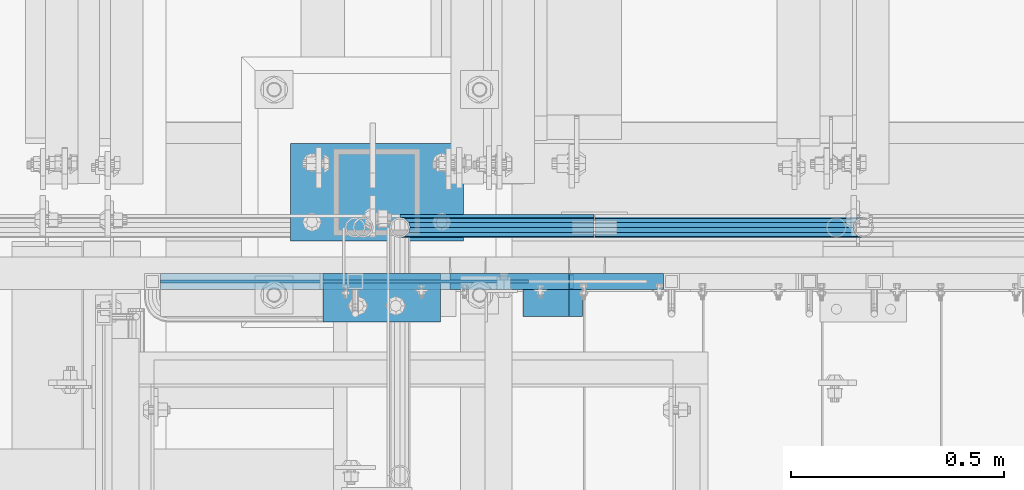
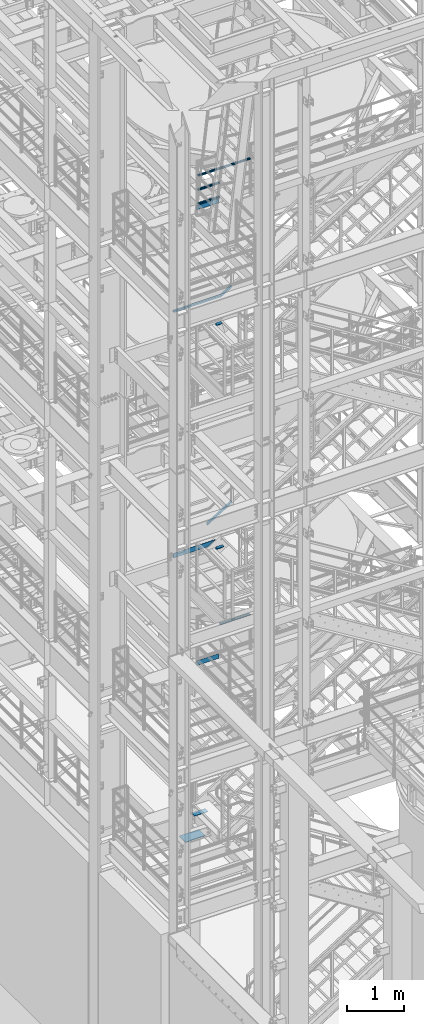
# One storey, part 1174 of 1876: 13 beams, 2 members, 10 elements without a shape of their own.
"""IFC2X3 building model written with IfcOpenShell, lengths in millimetres."""

from ifc_helpers import new_model, si_unit, frame, origin_with_axes, place, context, subcontext, project, spatial, faceted_brep, material, type_object, element, aggregate, save


model = new_model("IFC2X3")

# Units and contexts
model_context = context("Model", 3, precision=1e-05, world=origin_with_axes())
body_context = subcontext(model_context, "Body", "Model", "MODEL_VIEW")
ifc_project = project(units=[si_unit("LENGTHUNIT", "METRE", prefix="MILLI"), si_unit("AREAUNIT", "SQUARE_METRE"), si_unit("VOLUMEUNIT", "CUBIC_METRE"), si_unit("MASSUNIT", "GRAM", prefix="KILO"), si_unit("TIMEUNIT", "SECOND"), si_unit("PLANEANGLEUNIT", "RADIAN"), si_unit("SOLIDANGLEUNIT", "STERADIAN"), si_unit("THERMODYNAMICTEMPERATUREUNIT", "DEGREE_CELSIUS"), si_unit("LUMINOUSINTENSITYUNIT", "LUMEN")], contexts=[model_context])

# Site, building, storey
site_placement = place(None, origin_with_axes())
site = spatial("IfcSite", under=ifc_project, at=site_placement, CompositionType="ELEMENT")
building_placement = place(site_placement, origin_with_axes())
building = spatial("IfcBuilding", under=site, at=building_placement, Name="Undefined", CompositionType="ELEMENT")
storey_placement = place(building_placement, origin_with_axes())
storey = spatial("IfcBuildingStorey", under=building, at=storey_placement, Name="Undefined", CompositionType="ELEMENT", Elevation=0.0)

# Assembly, beams
assembly_1_placement = place(storey_placement, origin_with_axes())
assembly_1 = element("IfcElementAssembly", 1, at=assembly_1_placement, inside=storey, Name="RAIL", AssemblyPlace="NOTDEFINED", PredefinedType="RIGID_FRAME")
ifc_material_1 = material()
beam_type_1 = type_object("IfcBeamType", Name="PIPE1-1/2SCH40", PredefinedType="NOTDEFINED")
beam_1_placement = place(assembly_1_placement, frame((1781.17499999995, -4654.55000114554, 18754.725), z_axis=(0.0, 0.0, 1.0), x_axis=(1.0, 0.0, 0.0)))
beam_1 = element("IfcBeam", 2, at=beam_1_placement, type_object=beam_type_1, material=ifc_material_1, Name="RAIL", ObjectType="PIPE1-1/2SCH40", context=body_context, shape_type="Brep", body=[
    faceted_brep([(0.0, 24.1299999999992, 0.0), (12.0650000000064, 20.8971929933177, -12.0649999999987), (12.0650000000064, 20.8971929933177, 12.0649999999987), (12.0650000000064, -20.8971929933177, 12.0649999999987), (12.0650000000064, -20.8971929933177, -12.0649999999987), (0.0, -24.1299999999992, 0.0), (20.8971929933249, -12.0650000000005, 20.8971929933177), (20.8971929933249, -12.0650000000005, 15.8661214311796), (15.2545715621445, -17.7076214311801, 10.2235000000001), (12.5151929933249, -20.4470000000001, 0.0), (15.2545715621445, -17.7076214311801, -10.2235000000001), (20.8971929933249, -12.0650000000005, -15.8661214311796), (20.8971929933249, -12.0650000000005, -20.8971929933177), (24.1300000000063, 0.0, -20.4470000000001), (24.1300000000063, 0.0, -24.130000000001), (21.3906214311868, -10.2235000000001, -17.7076214311819), (21.3906214311868, 10.2235000000001, -17.7076214311819), (20.8971929933249, 12.0650000000005, -15.8661214311796), (20.8971929933249, 12.0650000000005, -20.8971929933177), (15.2545715621445, 17.7076214311801, -10.2235000000001), (12.5151929933249, 20.4470000000001, 0.0), (15.2545715621445, 17.7076214311801, 10.2235000000001), (20.8971929933249, 12.0650000000005, 15.8661214311796), (20.8971929933249, 12.0650000000005, 20.8971929933177), (21.3906214311868, 10.2235000000001, 17.7076214311819), (24.1300000000064, 0.0, 20.4470000000001), (24.1300000000064, 0.0, 24.130000000001), (21.3906214311868, -10.2235000000001, 17.7076214311819), (455.612999922148, -24.1300000000001, 0.0), (455.612999922148, -20.8971929933186, 12.0649999999996), (455.612999922148, -12.0649999999996, 20.8971929933186), (455.612999922148, 0.0, 24.1300000000001), (455.612999922148, -12.0649999999996, -20.8971929933186), (455.612999922148, -20.8971929933186, -12.0649999999996), (455.612999922148, 0.0, -24.1300000000001), (455.612999922148, 12.0649999999996, -20.8971929933186), (455.612999922148, 20.8971929933186, -12.0649999999996), (455.612999922148, 24.1300000000001, 0.0), (455.612999922148, 20.8971929933186, 12.0649999999996), (455.612999922148, 12.0649999999996, 20.8971929933186), (455.612999922148, -10.2235000000001, 17.7076214311801), (455.612999922148, 0.0, 20.4470000000001), (455.612999922148, 10.2235000000001, 17.7076214311801), (455.612999922148, 17.7076214311801, 10.2235000000001), (455.612999922148, 20.4470000000001, 0.0), (455.612999922148, 17.7076214311801, -10.2235000000001), (455.612999922148, 10.2235000000001, -17.7076214311801), (455.612999922148, 0.0, -20.4470000000001), (455.612999922148, -10.2235000000001, -17.7076214311801), (455.612999922148, -17.7076214311801, -10.2235000000001), (455.612999922148, -20.4470000000001, 0.0), (455.612999922148, -17.7076214311801, 10.2235000000001)], [[[0, 1, 2]], [[3, 4, 5]], [[6, 7, 8, 9, 10, 11, 12, 4, 3]], [[13, 14, 12, 11, 15]], [[16, 17, 18, 14, 13]], [[2, 1, 18, 17, 19, 20, 21, 22, 23]], [[23, 22, 24, 25, 26]], [[26, 25, 27, 7, 6]], [[28, 29, 3, 5]], [[29, 30, 6, 3]], [[30, 31, 26, 6]], [[32, 33, 4, 12]], [[34, 32, 12, 14]], [[35, 34, 14, 18]], [[36, 35, 18, 1]], [[37, 36, 1, 0]], [[38, 37, 0, 2]], [[39, 38, 2, 23]], [[31, 39, 23, 26]], [[33, 28, 5, 4]], [[32, 34, 35, 36, 37, 38, 39, 31, 30, 29, 28, 33], [40, 41, 42, 43, 44, 45, 46, 47, 48, 49, 50, 51]], [[42, 41, 25, 24]], [[21, 43, 42, 24, 22]], [[44, 43, 21, 20]], [[45, 44, 20, 19]], [[46, 45, 19, 17, 16]], [[47, 46, 16, 13]], [[48, 47, 13, 15]], [[10, 49, 48, 15, 11]], [[50, 49, 10, 9]], [[51, 50, 9, 8]], [[40, 51, 8, 7, 27]], [[41, 40, 27, 25]]]),
])
beam_2_placement = place(assembly_1_placement, frame((1781.17499999995, -4654.55000114555, 18449.925), z_axis=(0.0, 0.0, 1.0), x_axis=(1.0, 0.0, 0.0)))
beam_2 = element("IfcBeam", 3, at=beam_2_placement, type_object=beam_type_1, material=ifc_material_1, Name="RAIL", ObjectType="PIPE1-1/2SCH40", context=body_context, shape_type="Brep", body=[
    faceted_brep([(0.0, 24.1299999999992, 0.0), (12.0650000000064, 20.8971929933177, -12.0649999999987), (12.0650000000064, 20.8971929933177, 12.0649999999987), (12.0650000000064, -20.8971929933177, 12.0649999999987), (12.0650000000064, -20.8971929933177, -12.0649999999987), (0.0, -24.1299999999992, 0.0), (20.8971929933249, -12.0650000000005, 20.8971929933177), (20.8971929933249, -12.0650000000005, 15.8661214311796), (15.2545715621445, -17.7076214311801, 10.2235000000001), (12.5151929933249, -20.4470000000001, 0.0), (15.2545715621445, -17.7076214311801, -10.2235000000001), (20.8971929933249, -12.0650000000005, -15.8661214311796), (20.8971929933249, -12.0650000000005, -20.8971929933177), (24.1300000000063, 0.0, -20.4470000000001), (24.1300000000063, 0.0, -24.130000000001), (21.3906214311868, -10.2235000000001, -17.7076214311819), (21.3906214311868, 10.2235000000001, -17.7076214311819), (20.8971929933249, 12.0650000000005, -15.8661214311796), (20.8971929933249, 12.0650000000005, -20.8971929933177), (15.2545715621445, 17.7076214311801, -10.2235000000001), (12.5151929933249, 20.4470000000001, 0.0), (15.2545715621445, 17.7076214311801, 10.2235000000001), (20.8971929933249, 12.0650000000005, 15.8661214311796), (20.8971929933249, 12.0650000000005, 20.8971929933177), (21.3906214311868, 10.2235000000001, 17.7076214311819), (24.1300000000064, 0.0, 20.4470000000001), (24.1300000000064, 0.0, 24.130000000001), (21.3906214311868, -10.2235000000001, 17.7076214311819), (455.612999922148, -24.1300000000001, 0.0), (455.612999922148, -20.8971929933186, 12.0649999999996), (455.612999922148, -12.0649999999996, 20.8971929933186), (455.612999922148, 0.0, 24.1300000000001), (455.612999922148, -12.0649999999996, -20.8971929933186), (455.612999922148, -20.8971929933186, -12.0649999999996), (455.612999922148, 0.0, -24.1300000000001), (455.612999922148, 12.0649999999996, -20.8971929933186), (455.612999922148, 20.8971929933186, -12.0649999999996), (455.612999922148, 24.1300000000001, 0.0), (455.612999922148, 20.8971929933186, 12.0649999999996), (455.612999922148, 12.0649999999996, 20.8971929933186), (455.612999922148, -10.2235000000001, 17.7076214311801), (455.612999922148, 0.0, 20.4470000000001), (455.612999922148, 10.2235000000001, 17.7076214311801), (455.612999922148, 17.7076214311801, 10.2235000000001), (455.612999922148, 20.4470000000001, 0.0), (455.612999922148, 17.7076214311801, -10.2235000000001), (455.612999922148, 10.2235000000001, -17.7076214311801), (455.612999922148, 0.0, -20.4470000000001), (455.612999922148, -10.2235000000001, -17.7076214311801), (455.612999922148, -17.7076214311801, -10.2235000000001), (455.612999922148, -20.4470000000001, 0.0), (455.612999922148, -17.7076214311801, 10.2235000000001)], [[[0, 1, 2]], [[3, 4, 5]], [[6, 7, 8, 9, 10, 11, 12, 4, 3]], [[13, 14, 12, 11, 15]], [[16, 17, 18, 14, 13]], [[2, 1, 18, 17, 19, 20, 21, 22, 23]], [[23, 22, 24, 25, 26]], [[26, 25, 27, 7, 6]], [[28, 29, 3, 5]], [[29, 30, 6, 3]], [[30, 31, 26, 6]], [[32, 33, 4, 12]], [[34, 32, 12, 14]], [[35, 34, 14, 18]], [[36, 35, 18, 1]], [[37, 36, 1, 0]], [[38, 37, 0, 2]], [[39, 38, 2, 23]], [[31, 39, 23, 26]], [[33, 28, 5, 4]], [[32, 34, 35, 36, 37, 38, 39, 31, 30, 29, 28, 33], [40, 41, 42, 43, 44, 45, 46, 47, 48, 49, 50, 51]], [[42, 41, 25, 24]], [[21, 43, 42, 24, 22]], [[44, 43, 21, 20]], [[45, 44, 20, 19]], [[46, 45, 19, 17, 16]], [[47, 46, 16, 13]], [[48, 47, 13, 15]], [[10, 49, 48, 15, 11]], [[50, 49, 10, 9]], [[51, 50, 9, 8]], [[40, 51, 8, 7, 27]], [[41, 40, 27, 25]]]),
])
beam_3_placement = place(assembly_1_placement, frame((1781.175, -4654.55000114554, 18145.125), z_axis=(0.0, 0.0, 1.0), x_axis=(1.0, 0.0, 0.0)))
beam_3 = element("IfcBeam", 4, at=beam_3_placement, type_object=beam_type_1, material=ifc_material_1, Name="RAIL", ObjectType="PIPE1-1/2SCH40", context=body_context, shape_type="Brep", body=[
    faceted_brep([(0.0, 24.1299999999992, 0.0), (12.0650000000064, 20.8971929933177, -12.0649999999987), (12.0650000000064, 20.8971929933177, 12.0649999999987), (12.0650000000064, -20.8971929933177, 12.0649999999987), (12.0650000000064, -20.8971929933177, -12.0649999999987), (0.0, -24.1299999999992, 0.0), (20.8971929933249, -12.0650000000005, 20.8971929933177), (20.8971929933249, -12.0650000000005, 15.8661214311796), (15.2545715621445, -17.7076214311801, 10.2235000000001), (12.5151929933249, -20.4470000000001, 0.0), (15.2545715621445, -17.7076214311801, -10.2235000000001), (20.8971929933249, -12.0650000000005, -15.8661214311796), (20.8971929933249, -12.0650000000005, -20.8971929933177), (24.1300000000063, 0.0, -20.4470000000001), (24.1300000000063, 0.0, -24.130000000001), (21.3906214311868, -10.2235000000001, -17.7076214311819), (21.3906214311868, 10.2235000000001, -17.7076214311819), (20.8971929933249, 12.0650000000005, -15.8661214311796), (20.8971929933249, 12.0650000000005, -20.8971929933177), (15.2545715621445, 17.7076214311801, -10.2235000000001), (12.5151929933249, 20.4470000000001, 0.0), (15.2545715621445, 17.7076214311801, 10.2235000000001), (20.8971929933249, 12.0650000000005, 15.8661214311796), (20.8971929933249, 12.0650000000005, 20.8971929933177), (21.3906214311868, 10.2235000000001, 17.7076214311819), (24.1300000000064, 0.0, 20.4470000000001), (24.1300000000064, 0.0, 24.130000000001), (21.3906214311868, -10.2235000000001, 17.7076214311819), (455.612999922148, -24.1300000000001, 0.0), (455.612999922148, -20.8971929933186, 12.0649999999996), (455.612999922148, -12.0649999999996, 20.8971929933186), (455.612999922148, 0.0, 24.1300000000001), (455.612999922148, -12.0649999999996, -20.8971929933186), (455.612999922148, -20.8971929933186, -12.0649999999996), (455.612999922148, 0.0, -24.1300000000001), (455.612999922148, 12.0649999999996, -20.8971929933186), (455.612999922148, 20.8971929933186, -12.0649999999996), (455.612999922148, 24.1300000000001, 0.0), (455.612999922148, 20.8971929933186, 12.0649999999996), (455.612999922148, 12.0649999999996, 20.8971929933186), (455.612999922148, -10.2235000000001, 17.7076214311801), (455.612999922148, 0.0, 20.4470000000001), (455.612999922148, 10.2235000000001, 17.7076214311801), (455.612999922148, 17.7076214311801, 10.2235000000001), (455.612999922148, 20.4470000000001, 0.0), (455.612999922148, 17.7076214311801, -10.2235000000001), (455.612999922148, 10.2235000000001, -17.7076214311801), (455.612999922148, 0.0, -20.4470000000001), (455.612999922148, -10.2235000000001, -17.7076214311801), (455.612999922148, -17.7076214311801, -10.2235000000001), (455.612999922148, -20.4470000000001, 0.0), (455.612999922148, -17.7076214311801, 10.2235000000001)], [[[0, 1, 2]], [[3, 4, 5]], [[6, 7, 8, 9, 10, 11, 12, 4, 3]], [[13, 14, 12, 11, 15]], [[16, 17, 18, 14, 13]], [[2, 1, 18, 17, 19, 20, 21, 22, 23]], [[23, 22, 24, 25, 26]], [[26, 25, 27, 7, 6]], [[28, 29, 3, 5]], [[29, 30, 6, 3]], [[30, 31, 26, 6]], [[32, 33, 4, 12]], [[34, 32, 12, 14]], [[35, 34, 14, 18]], [[36, 35, 18, 1]], [[37, 36, 1, 0]], [[38, 37, 0, 2]], [[39, 38, 2, 23]], [[31, 39, 23, 26]], [[33, 28, 5, 4]], [[32, 34, 35, 36, 37, 38, 39, 31, 30, 29, 28, 33], [40, 41, 42, 43, 44, 45, 46, 47, 48, 49, 50, 51]], [[42, 41, 25, 24]], [[21, 43, 42, 24, 22]], [[44, 43, 21, 20]], [[45, 44, 20, 19]], [[46, 45, 19, 17, 16]], [[47, 46, 16, 13]], [[48, 47, 13, 15]], [[10, 49, 48, 15, 11]], [[50, 49, 10, 9]], [[51, 50, 9, 8]], [[40, 51, 8, 7, 27]], [[41, 40, 27, 25]]]),
])

# Assembly, beam
assembly_2_placement = place(storey_placement, origin_with_axes())
assembly_2 = element("IfcElementAssembly", 5, at=assembly_2_placement, inside=storey, Name="RAIL", AssemblyPlace="NOTDEFINED", PredefinedType="RIGID_FRAME")
beam_4_placement = place(assembly_2_placement, frame((2238.37499998823, -4654.55000114554, 8924.925), z_axis=(0.0, 0.0, -1.0), x_axis=(1.0, 0.0, 0.0)))
beam_4 = element("IfcBeam", 6, at=beam_4_placement, type_object=beam_type_1, material=ifc_material_1, Name="RAIL", ObjectType="PIPE1-1/2SCH40", context=body_context, shape_type="Brep", body=[
    faceted_brep([(610.92780700668, -12.0649999999996, 20.8971929933177), (610.92780700668, -12.0650000000051, 15.866121431176), (610.434378568817, -10.2235000000001, 17.7076214311819), (607.694999999998, 0.0, 20.4470000000001), (607.694999999998, 0.0, 24.130000000001), (610.434378568819, 10.2235000000001, 17.7076214311819), (610.92780700668, 12.0649999999941, 15.8661214311869), (610.92780700668, 12.0649999999996, 20.8971929933177), (631.825, 24.1300000000001, 0.0), (619.759999999998, 20.8971929933186, 12.0649999999987), (619.759999999998, 20.8971929933186, -12.0649999999987), (616.570428437866, 17.7076214311801, 10.2235000000001), (619.309807006685, 20.4470000000001, 0.0), (616.570428437866, 17.7076214311801, -10.2235000000001), (610.92780700668, 12.0649999999941, -15.8661214311869), (610.92780700668, 12.0649999999996, -20.8971929933177), (610.434378568819, 10.2235000000001, -17.7076214311819), (607.694999999998, 0.0, -20.4470000000001), (607.694999999998, 0.0, -24.130000000001), (610.92780700668, -12.0650000000051, -15.866121431176), (610.92780700668, -12.0649999999996, -20.8971929933177), (610.434378568817, -10.2235000000001, -17.7076214311819), (631.824999999998, -24.1300000000056, 0.0), (619.759999999998, -20.8971929933186, -12.0649999999987), (619.759999999998, -20.8971929933186, 12.0649999999987), (616.570428437855, -17.7076214311801, -10.2235000000001), (619.309807006674, -20.4470000000001, 0.0), (616.570428437855, -17.7076214311801, 10.2235000000001), (1.58700000000044, -20.8971929933186, -12.0649999999996), (1.58700000000044, -12.0649999999996, -20.8971929933186), (1.58700000000044, 0.0, -24.1300000000001), (1.58700000000044, 12.0649999999996, -20.8971929933186), (1.58700000000044, 20.8971929933186, -12.0649999999996), (1.58700000000044, 24.1300000000001, 0.0), (1.58700000000044, 20.8971929933186, 12.0649999999996), (1.58700000000044, 12.0649999999996, 20.8971929933186), (1.58700000000044, 0.0, 24.1300000000001), (1.58700000000044, -12.0649999999996, 20.8971929933186), (1.58700000000044, -20.8971929933186, 12.0649999999996), (1.58700000000044, -24.1300000000001, 0.0), (1.58700000000044, -17.7076214311801, -10.2235000000001), (1.58700000000044, -10.2235000000001, -17.7076214311801), (1.58700000000044, 0.0, -20.4470000000001), (1.58700000000044, 10.2235000000001, -17.7076214311801), (1.58700000000044, 17.7076214311801, -10.2235000000001), (1.58700000000044, 20.4470000000001, 0.0), (1.58700000000044, 17.7076214311801, 10.2235000000001), (1.58700000000044, 10.2235000000001, 17.7076214311801), (1.58700000000044, 0.0, 20.4470000000001), (1.58700000000044, -10.2235000000001, 17.7076214311801), (1.58700000000044, -17.7076214311801, 10.2235000000001), (1.58700000000044, -20.4470000000001, 0.0)], [[[0, 1, 2, 3, 4]], [[4, 3, 5, 6, 7]], [[8, 9, 10]], [[7, 6, 11, 12, 13, 14, 15, 10, 9]], [[16, 17, 18, 15, 14]], [[19, 20, 18, 17, 21]], [[22, 23, 24]], [[24, 23, 20, 19, 25, 26, 27, 1, 0]], [[28, 29, 20, 23]], [[29, 30, 18, 20]], [[30, 31, 15, 18]], [[31, 32, 10, 15]], [[32, 33, 8, 10]], [[33, 34, 9, 8]], [[34, 35, 7, 9]], [[35, 36, 4, 7]], [[36, 37, 0, 4]], [[37, 38, 24, 0]], [[38, 39, 22, 24]], [[39, 28, 23, 22]], [[38, 37, 36, 35, 34, 33, 32, 31, 30, 29, 28, 39], [40, 41, 42, 43, 44, 45, 46, 47, 48, 49, 50, 51]], [[40, 51, 26, 25]], [[21, 41, 40, 25, 19]], [[42, 41, 21, 17]], [[43, 42, 17, 16]], [[44, 43, 16, 14, 13]], [[45, 44, 13, 12]], [[46, 45, 12, 11]], [[5, 47, 46, 11, 6]], [[48, 47, 5, 3]], [[49, 48, 3, 2]], [[50, 49, 2, 1, 27]], [[51, 50, 27, 26]]]),
])
aggregate(assembly_2, [beam_4])

assembly_3_placement = place(storey_placement, origin_with_axes())
assembly_3 = element("IfcElementAssembly", 7, at=assembly_3_placement, inside=storey, Name="RAIL", AssemblyPlace="NOTDEFINED", PredefinedType="RIGID_FRAME")
beam_5_placement = place(assembly_3_placement, frame((2238.37499998823, -4654.55000114554, 18754.725), z_axis=(0.0, 0.0, -1.0), x_axis=(1.0, 0.0, 0.0)))
beam_5 = element("IfcBeam", 8, at=beam_5_placement, type_object=beam_type_1, material=ifc_material_1, Name="RAIL", ObjectType="PIPE1-1/2SCH40", context=body_context, shape_type="Brep", body=[
    faceted_brep([(610.92780700668, -12.0649999999996, 20.8971929933177), (610.92780700668, -12.0650000000051, 15.866121431176), (610.434378568817, -10.2235000000001, 17.7076214311819), (607.694999999998, 0.0, 20.4470000000001), (607.694999999998, 0.0, 24.130000000001), (610.434378568819, 10.2235000000001, 17.7076214311819), (610.92780700668, 12.0649999999941, 15.8661214311869), (610.92780700668, 12.0649999999996, 20.8971929933177), (631.825, 24.1300000000001, 0.0), (619.759999999998, 20.8971929933186, 12.0649999999987), (619.759999999998, 20.8971929933186, -12.0649999999987), (616.570428437866, 17.7076214311801, 10.2235000000001), (619.309807006685, 20.4470000000001, 0.0), (616.570428437866, 17.7076214311801, -10.2235000000001), (610.92780700668, 12.0649999999941, -15.8661214311869), (610.92780700668, 12.0649999999996, -20.8971929933177), (610.434378568819, 10.2235000000001, -17.7076214311819), (607.694999999998, 0.0, -20.4470000000001), (607.694999999998, 0.0, -24.130000000001), (610.92780700668, -12.0650000000051, -15.866121431176), (610.92780700668, -12.0649999999996, -20.8971929933177), (610.434378568817, -10.2235000000001, -17.7076214311819), (631.824999999998, -24.1300000000056, 0.0), (619.759999999998, -20.8971929933186, -12.0649999999987), (619.759999999998, -20.8971929933186, 12.0649999999987), (616.570428437855, -17.7076214311801, -10.2235000000001), (619.309807006674, -20.4470000000001, 0.0), (616.570428437855, -17.7076214311801, 10.2235000000001), (1.58700000000044, -20.8971929933186, -12.0649999999996), (1.58700000000044, -12.0649999999996, -20.8971929933186), (1.58700000000044, 0.0, -24.1300000000001), (1.58700000000044, 12.0649999999996, -20.8971929933186), (1.58700000000044, 20.8971929933186, -12.0649999999996), (1.58700000000044, 24.1300000000001, 0.0), (1.58700000000044, 20.8971929933186, 12.0649999999996), (1.58700000000044, 12.0649999999996, 20.8971929933186), (1.58700000000044, 0.0, 24.1300000000001), (1.58700000000044, -12.0649999999996, 20.8971929933186), (1.58700000000044, -20.8971929933186, 12.0649999999996), (1.58700000000044, -24.1300000000001, 0.0), (1.58700000000044, -17.7076214311801, -10.2235000000001), (1.58700000000044, -10.2235000000001, -17.7076214311801), (1.58700000000044, 0.0, -20.4470000000001), (1.58700000000044, 10.2235000000001, -17.7076214311801), (1.58700000000044, 17.7076214311801, -10.2235000000001), (1.58700000000044, 20.4470000000001, 0.0), (1.58700000000044, 17.7076214311801, 10.2235000000001), (1.58700000000044, 10.2235000000001, 17.7076214311801), (1.58700000000044, 0.0, 20.4470000000001), (1.58700000000044, -10.2235000000001, 17.7076214311801), (1.58700000000044, -17.7076214311801, 10.2235000000001), (1.58700000000044, -20.4470000000001, 0.0)], [[[0, 1, 2, 3, 4]], [[4, 3, 5, 6, 7]], [[8, 9, 10]], [[7, 6, 11, 12, 13, 14, 15, 10, 9]], [[16, 17, 18, 15, 14]], [[19, 20, 18, 17, 21]], [[22, 23, 24]], [[24, 23, 20, 19, 25, 26, 27, 1, 0]], [[28, 29, 20, 23]], [[29, 30, 18, 20]], [[30, 31, 15, 18]], [[31, 32, 10, 15]], [[32, 33, 8, 10]], [[33, 34, 9, 8]], [[34, 35, 7, 9]], [[35, 36, 4, 7]], [[36, 37, 0, 4]], [[37, 38, 24, 0]], [[38, 39, 22, 24]], [[39, 28, 23, 22]], [[38, 37, 36, 35, 34, 33, 32, 31, 30, 29, 28, 39], [40, 41, 42, 43, 44, 45, 46, 47, 48, 49, 50, 51]], [[40, 51, 26, 25]], [[21, 41, 40, 25, 19]], [[42, 41, 21, 17]], [[43, 42, 17, 16]], [[44, 43, 16, 14, 13]], [[45, 44, 13, 12]], [[46, 45, 12, 11]], [[5, 47, 46, 11, 6]], [[48, 47, 5, 3]], [[49, 48, 3, 2]], [[50, 49, 2, 1, 27]], [[51, 50, 27, 26]]]),
])
aggregate(assembly_3, [beam_5])

assembly_4_placement = place(storey_placement, origin_with_axes())
assembly_4 = element("IfcElementAssembly", 9, at=assembly_4_placement, inside=storey, Name="STRINGER", AssemblyPlace="NOTDEFINED", PredefinedType="RIGID_FRAME")
ifc_material_2 = material(Name="STEEL/A36")
beam_type_2 = type_object("IfcBeamType", Name="L2-1/2X2-1/2X1/4", PredefinedType="NOTDEFINED")
beam_6_placement = place(assembly_4_placement, frame((2070.10000004636, -4832.34999887687, 15531.2768518519), z_axis=(0.0, -1.0, 0.0), x_axis=(1.0, 0.0, 0.0)))
beam_6 = element("IfcBeam", 10, at=beam_6_placement, type_object=beam_type_2, material=ifc_material_2, Name="ANGLE", ObjectType="L2-1/2X2-1/2X1/4", context=body_context, shape_type="Brep", body=[
    faceted_brep([(0.0, 31.75, -31.75), (0.0, 31.75, 31.75), (107.95007324219, 31.7500000000491, 31.75), (107.95007324219, 31.7500000000491, -31.75), (0.0, 25.3999999999996, 31.75), (107.950073242189, 25.4000000000487, 31.75), (0.0, 25.3999999999996, -25.3999999999996), (107.950073242189, 25.4000000000487, -25.3999999999996), (0.0, -31.75, -25.3999999999996), (107.950073242189, -31.7499999999509, -25.3999999999996), (0.0, -31.75, -31.75), (107.950073242189, -31.7499999999509, -31.75)], [[[0, 1, 2, 3]], [[1, 4, 5, 2]], [[4, 6, 7, 5]], [[6, 8, 9, 7]], [[8, 10, 11, 9]], [[10, 0, 3, 11]], [[5, 7, 9, 11, 3, 2]], [[10, 8, 6, 4, 1, 0]]]),
])
aggregate(assembly_4, [beam_6])

assembly_5_placement = place(storey_placement, origin_with_axes())
assembly_5 = element("IfcElementAssembly", 11, at=assembly_5_placement, inside=storey, Name="STRINGER", AssemblyPlace="NOTDEFINED", PredefinedType="RIGID_FRAME")
beam_7_placement = place(assembly_5_placement, frame((2070.1000003697, -4832.34999887637, 10702.925), z_axis=(0.0, -1.0, 0.0), x_axis=(1.0, 0.0, 0.0)))
beam_7 = element("IfcBeam", 12, at=beam_7_placement, type_object=beam_type_2, material=ifc_material_2, Name="ANGLE", ObjectType="L2-1/2X2-1/2X1/4", context=body_context, shape_type="Brep", body=[
    faceted_brep([(0.0, 31.75, -31.75), (0.0, 31.75, 31.75), (139.700073242188, 31.75, 31.75), (139.700073242188, 31.75, -31.75), (0.0, 25.3999999999996, 31.75), (139.700073242188, 25.3999999999996, 31.75), (0.0, 25.3999999999996, -25.3999999999996), (139.700073242188, 25.3999999999996, -25.3999999999996), (0.0, -31.75, -25.3999999999996), (139.700073242188, -31.75, -25.3999999999996), (0.0, -31.75, -31.75), (139.700073242188, -31.75, -31.75)], [[[0, 1, 2, 3]], [[1, 4, 5, 2]], [[4, 6, 7, 5]], [[6, 8, 9, 7]], [[8, 10, 11, 9]], [[10, 0, 3, 11]], [[5, 7, 9, 11, 3, 2]], [[10, 8, 6, 4, 1, 0]]]),
])
aggregate(assembly_5, [beam_7])

assembly_6_placement = place(storey_placement, origin_with_axes())
assembly_6 = element("IfcElementAssembly", 13, at=assembly_6_placement, inside=storey, Name="RAIL", AssemblyPlace="NOTDEFINED", PredefinedType="RIGID_FRAME")
beam_type_3 = type_object("IfcBeamType", PredefinedType="NOTDEFINED")
beam_8_placement = place(assembly_6_placement, frame((1781.175, -4627.56250191054, 8220.075), z_axis=(0.0, 0.0, 1.0), x_axis=(1.0, 0.0, 0.0)))
beam_8 = element("IfcBeam", 14, at=beam_8_placement, type_object=beam_type_3, material=ifc_material_2, Name="PLATE", context=body_context, shape_type="Brep", body=[
    faceted_brep([(0.0, 3.17500000000018, -50.8000000000002), (0.0, 3.17500000000018, 50.8000000000002), (455.612499988232, 3.17500000000018, 50.7999999999993), (455.612499988232, 3.17500000000018, -50.8000000000002), (0.0, -3.17500000000018, 50.8000000000002), (455.612499988232, -3.17500000000018, 50.7999999999993), (0.0, -3.17500000000018, -50.8000000000002), (455.612499988232, -3.17500000000018, -50.8000000000002)], [[[0, 1, 2, 3]], [[1, 4, 5, 2]], [[4, 6, 7, 5]], [[6, 0, 3, 7]], [[5, 7, 3, 2]], [[6, 4, 1, 0]]]),
])
aggregate(assembly_6, [beam_8])

# Beam
beam_9_placement = place(assembly_1_placement, frame((1781.175, -4627.56250191054, 18049.875), z_axis=(0.0, 0.0, 1.0), x_axis=(1.0, 0.0, 0.0)))
beam_9 = element("IfcBeam", 15, at=beam_9_placement, type_object=beam_type_3, material=ifc_material_2, Name="PLATE", context=body_context, shape_type="Brep", body=[
    faceted_brep([(0.0, 3.17500000000018, -50.8000000000002), (0.0, 3.17500000000018, 50.8000000000002), (455.612499988232, 3.17500000000018, 50.7999999999993), (455.612499988232, 3.17500000000018, -50.8000000000002), (0.0, -3.17500000000018, 50.8000000000002), (455.612499988232, -3.17500000000018, 50.7999999999993), (0.0, -3.17500000000018, -50.8000000000002), (455.612499988232, -3.17500000000018, -50.8000000000002)], [[[0, 1, 2, 3]], [[1, 4, 5, 2]], [[4, 6, 7, 5]], [[6, 0, 3, 7]], [[5, 7, 3, 2]], [[6, 4, 1, 0]]]),
])

aggregate(assembly_1, [beam_1, beam_2, beam_3, beam_9])

# Assembly, beam
assembly_7_placement = place(storey_placement, origin_with_axes())
assembly_7 = element("IfcElementAssembly", 16, at=assembly_7_placement, inside=storey, Name="RAIL", AssemblyPlace="NOTDEFINED", PredefinedType="RIGID_FRAME")
beam_10_placement = place(assembly_7_placement, frame((1219.19999961062, -4781.55000191421, 10829.9249989614), z_axis=(0.0, 0.0, 1.0), x_axis=(1.0, 0.0, 0.0)))
beam_10 = element("IfcBeam", 17, at=beam_10_placement, type_object=beam_type_3, material=ifc_material_2, Name="PLATE", context=body_context, shape_type="Brep", body=[
    faceted_brep([(0.0, 3.17500000000018, -50.8000000000002), (0.0, 3.17500000000018, 50.8000000000002), (864.420929595873, 3.17500000000018, 50.7999999999993), (699.258368074921, 3.17500000000018, -50.7999999999993), (0.0, -3.17500000000018, 50.8000000000002), (864.420929595873, -3.17500000000018, 50.7999999999993), (0.0, -3.17500000000018, -50.8000000000002), (699.258368074921, -3.17500000000018, -50.7999999999993)], [[[0, 1, 2, 3]], [[1, 4, 5, 2]], [[4, 6, 7, 5]], [[6, 0, 3, 7]], [[5, 7, 3, 2]], [[6, 4, 1, 0]]]),
])

assembly_8_placement = place(storey_placement, origin_with_axes())
assembly_8 = element("IfcElementAssembly", 18, at=assembly_8_placement, inside=storey, Name="RAIL", AssemblyPlace="NOTDEFINED", PredefinedType="RIGID_FRAME")
ifc_material_3 = material()
beam_type_4 = type_object("IfcBeamType", Name="HSS1-1/2X1-1/2X1/8", PredefinedType="NOTDEFINED")
beam_11_placement = place(assembly_8_placement, frame((1181.10000065765, -4781.55000114554, 16102.7768516247), z_axis=(0.0, 0.0, 1.0), x_axis=(1.0, 0.0, 0.0)))
beam_11 = element("IfcBeam", 19, at=beam_11_placement, type_object=beam_type_4, material=ifc_material_3, Name="RAIL", ObjectType="HSS1-1/2X1-1/2X1/8", context=body_context, shape_type="Brep", body=[
    faceted_brep([(38.0999984689179, 15.8749992829999, -15.8749992829999), (38.0999984689179, -15.8749992829999, -15.8749992829999), (1007.58397060773, -15.8749992829999, -15.8749992829999), (1007.58397060773, 15.8749992829999, -15.8749992829999), (38.0999984689179, -15.8749992829999, 15.8749992829999), (998.546376624249, -15.8749992829999, 15.8749992829999), (38.0999984689179, 15.8749992829999, 15.8749992829999), (998.546376624249, 15.8749992829999, 15.8749992829999), (38.0999984689179, 19.0499992349996, -19.0499992350001), (38.0999984699993, 19.0499992349996, 19.0499992350001), (997.642617198745, 19.0499992349996, 19.0499992349996), (1008.48773003324, 19.0499992349996, -19.0499992349996), (38.0999984699993, -19.0499992349996, 19.0499992350001), (997.642617198745, -19.0499992349996, 19.0499992349996), (38.0999984689179, -19.0499992349996, -19.0499992350001), (1008.48773003324, -19.0499992349996, -19.0499992349996)], [[[0, 1, 2, 3]], [[1, 4, 5, 2]], [[4, 6, 7, 5]], [[6, 0, 3, 7]], [[8, 9, 10, 11]], [[9, 12, 13, 10]], [[12, 14, 15, 13]], [[14, 8, 11, 15]], [[13, 15, 11, 10], [5, 7, 3, 2]], [[14, 12, 9, 8], [6, 4, 1, 0]]]),
])

# Member
member_type = type_object("IfcMemberType", Name="HSS1-1/2X1-1/2X1/8", PredefinedType="NOTDEFINED")
member_1_placement = place(assembly_7_placement, frame((1904.99999969936, -4781.55000114554, 11274.4249989618), z_axis=(-0.523953411146183, 0.0, 0.851746924237639), x_axis=(0.851746924237639, 0.0, 0.523953411146184)))
member_1 = element("IfcMember", 20, at=member_1_placement, type_object=member_type, material=ifc_material_3, Name="RAIL", ObjectType="HSS1-1/2X1-1/2X1/8", context=body_context, shape_type="Brep", body=[
    faceted_brep([(-4.49184492785935, 15.8749992829999, -15.8749992829999), (-4.49184492785935, -15.8749992829999, -15.8749992829999), (571.745230339588, -15.8749992829999, -15.8749992830653), (571.745230339588, 15.8749992829999, -15.8749992830653), (4.49184492431232, -15.8749992829999, 15.8749992829999), (591.276290070064, -15.8749992829999, 15.8749992829398), (4.49184492431232, 15.8749992829999, 15.8749992829999), (591.276290070064, 15.8749992829999, 15.8749992829398), (-5.39021394007068, 19.0499992349996, -19.0499992349996), (5.39021393652274, 19.0499992349996, 19.0499992349996), (593.229396101795, 19.0499992349996, 19.0499992349396), (569.792124307854, 19.0499992349996, -19.0499992350688), (5.39021393652274, -19.0499992349996, 19.0499992349996), (593.229396101795, -19.0499992349996, 19.0499992349396), (-5.39021394007068, -19.0499992349996, -19.0499992349996), (569.792124307854, -19.0499992349996, -19.0499992350688)], [[[0, 1, 2, 3]], [[1, 4, 5, 2]], [[4, 6, 7, 5]], [[6, 0, 3, 7]], [[8, 9, 10, 11]], [[9, 12, 13, 10]], [[12, 14, 15, 13]], [[14, 8, 11, 15]], [[13, 15, 11, 10], [5, 7, 3, 2]], [[14, 12, 9, 8], [6, 4, 1, 0]]]),
])

aggregate(assembly_7, [beam_10, member_1])

member_2_placement = place(assembly_8_placement, frame((2184.16517426012, -4781.55000114554, 16102.7768516303), z_axis=(-0.526627379729772, 0.0, 0.850096231563789), x_axis=(0.850096231563789, 0.0, 0.526627379729772)))
member_2 = element("IfcMember", 21, at=member_2_placement, type_object=member_type, material=ifc_material_3, Name="RAIL", ObjectType="HSS1-1/2X1-1/2X1/8", context=body_context, shape_type="Brep", body=[
    faceted_brep([(-4.5187969689996, 15.8749992829999, -15.8749992829871), (-4.5187969689996, -15.8749992829999, -15.8749992829871), (244.413055138222, -15.8749992829999, -15.8749992830089), (244.413055138222, 15.8749992829999, -15.8749992830089), (4.51879699284473, -15.8749992829999, 15.8749992829871), (264.081909004897, -15.8749992829999, 15.8749992829617), (4.51879699284473, 15.8749992829999, 15.8749992829871), (264.081909004897, 15.8749992829999, 15.8749992829617), (-5.42255639234099, 19.0499992349996, -19.0499992349833), (5.42255641618613, 19.0499992349996, 19.0499992349851), (266.048794450666, 19.0499992349996, 19.0499992349596), (242.446169692455, 19.0499992349996, -19.0499992350087), (5.42255641618613, -19.0499992349996, 19.0499992349851), (266.048794450666, -19.0499992349996, 19.0499992349596), (-5.42255639234099, -19.0499992349996, -19.0499992349833), (242.446169692455, -19.0499992349996, -19.0499992350087)], [[[0, 1, 2, 3]], [[1, 4, 5, 2]], [[4, 6, 7, 5]], [[6, 0, 3, 7]], [[8, 9, 10, 11]], [[9, 12, 13, 10]], [[12, 14, 15, 13]], [[14, 8, 11, 15]], [[13, 15, 11, 10], [5, 7, 3, 2]], [[14, 12, 9, 8], [6, 4, 1, 0]]]),
])

aggregate(assembly_8, [beam_11, member_2])

# Assembly, beam
assembly_9_placement = place(storey_placement, origin_with_axes())
assembly_9 = element("IfcElementAssembly", 22, at=assembly_9_placement, inside=storey, Name="STRINGER", AssemblyPlace="NOTDEFINED", PredefinedType="RIGID_FRAME")
beam_type_5 = type_object("IfcBeamType", PredefinedType="NOTDEFINED")
beam_12_placement = place(assembly_9_placement, frame((1876.42499918269, -4819.65000113109, 5133.97499991051), z_axis=(0.0, -1.0, 0.0), x_axis=(-1.0, 0.0, 0.0)))
beam_12 = element("IfcBeam", 23, at=beam_12_placement, type_object=beam_type_5, material=ifc_material_2, Name="PLATE", context=body_context, shape_type="Brep", body=[
    faceted_brep([(0.0, 3.17499999999927, -57.1499999999996), (0.0, 3.17499999999927, 57.1499999999996), (276.225, 3.17500000000018, 57.1499999999996), (276.225, 3.17500000000018, -57.1499999999996), (0.0, -3.17499999999927, 57.1499999999996), (276.225, -3.17500000000018, 57.1499999999996), (0.0, -3.17499999999927, -57.1499999999996), (276.225, -3.17500000000018, -57.1499999999996)], [[[0, 1, 2, 3]], [[1, 4, 5, 2]], [[4, 6, 7, 5]], [[6, 0, 3, 7]], [[5, 7, 3, 2]], [[6, 4, 1, 0]]]),
])
aggregate(assembly_9, [beam_12])

assembly_10_placement = place(storey_placement, origin_with_axes())
assembly_10 = element("IfcElementAssembly", 24, at=assembly_10_placement, inside=storey, Name="COLUMN", AssemblyPlace="NOTDEFINED", PredefinedType="RIGID_FRAME")
beam_type_6 = type_object("IfcBeamType", PredefinedType="NOTDEFINED")
beam_13_placement = place(assembly_10_placement, frame((1524.0, -4572.0, 4476.75), z_axis=(0.0, -1.0, 0.0), x_axis=(1.0, 0.0, 0.0)))
beam_13 = element("IfcBeam", 25, at=beam_13_placement, type_object=beam_type_6, material=ifc_material_2, Name="PLATE", context=body_context, shape_type="Brep", body=[
    faceted_brep([(0.0, 6.35000000000036, -114.3), (0.0, 6.35000000000036, 114.3), (406.4, 6.35000000000036, 114.3), (406.4, 6.35000000000036, -114.3), (0.0, -6.35000000000036, 114.3), (406.4, -6.35000000000036, 114.3), (0.0, -6.35000000000036, -114.3), (406.4, -6.35000000000036, -114.3)], [[[0, 1, 2, 3]], [[1, 4, 5, 2]], [[4, 6, 7, 5]], [[6, 0, 3, 7]], [[5, 7, 3, 2]], [[6, 4, 1, 0]]]),
])
aggregate(assembly_10, [beam_13])

save(model, "model.ifc")
